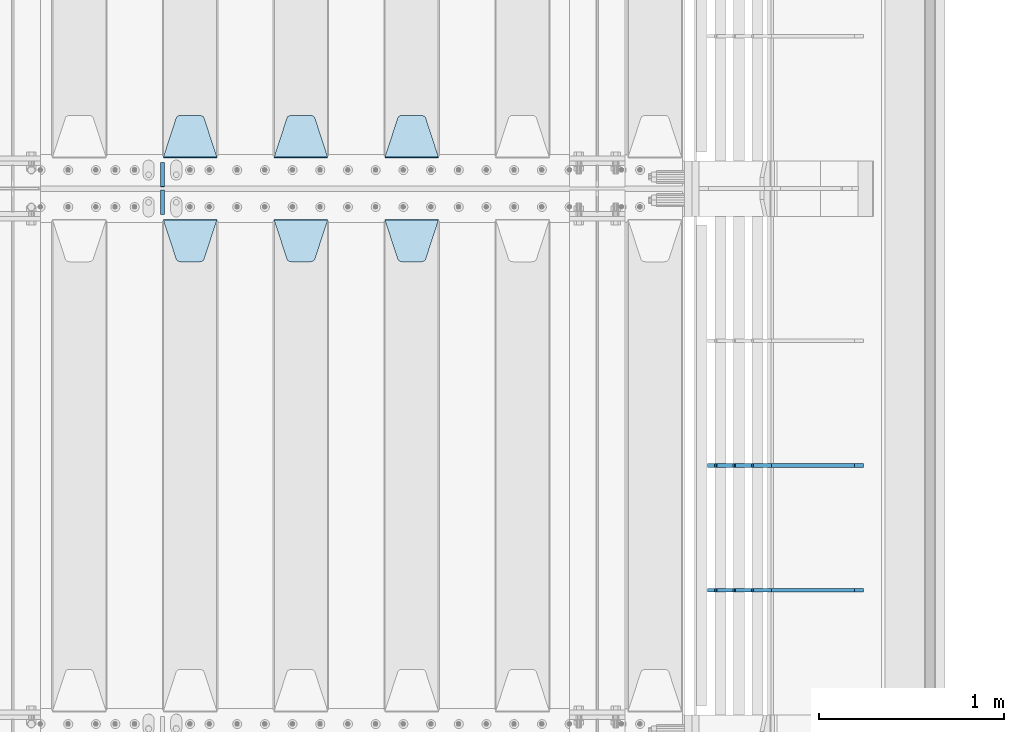
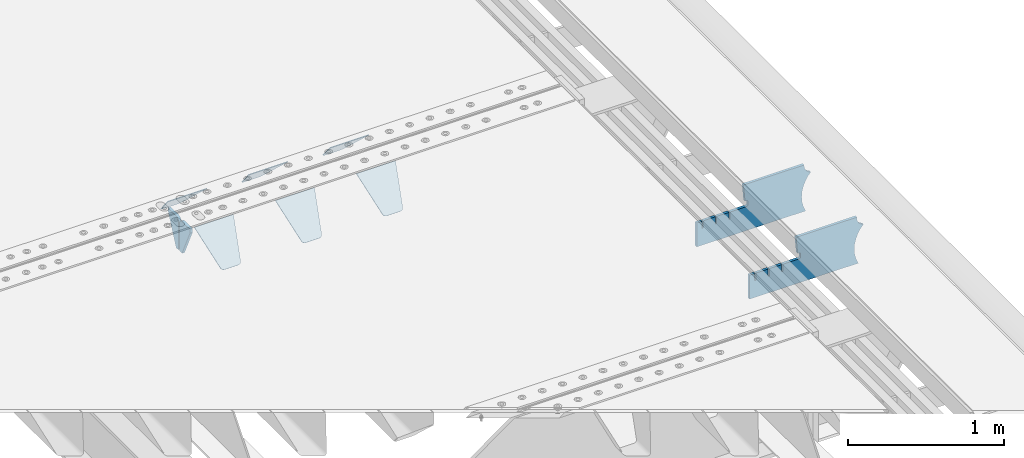
# One storey, part 207 of 240: 10 plates.
"""IFC2X3 building model written with IfcOpenShell, lengths in millimetres."""

from ifc_helpers import new_model, si_unit, frame, origin_with_axes, place, context, subcontext, project, spatial, faceted_brep, material, type_object, element, save


model = new_model("IFC2X3")

# Units and contexts
model_context = context("Model", 3, precision=1e-05, world=origin_with_axes())
body_context = subcontext(model_context, "Body", "Model", "MODEL_VIEW")
ifc_project = project(units=[si_unit("LENGTHUNIT", "METRE", prefix="MILLI"), si_unit("AREAUNIT", "SQUARE_METRE"), si_unit("VOLUMEUNIT", "CUBIC_METRE"), si_unit("MASSUNIT", "GRAM", prefix="KILO"), si_unit("TIMEUNIT", "SECOND"), si_unit("PLANEANGLEUNIT", "RADIAN"), si_unit("SOLIDANGLEUNIT", "STERADIAN"), si_unit("THERMODYNAMICTEMPERATUREUNIT", "DEGREE_CELSIUS"), si_unit("LUMINOUSINTENSITYUNIT", "LUMEN")], contexts=[model_context])

# Site, building, storey
site_placement = place(None, origin_with_axes())
site = spatial("IfcSite", under=ifc_project, at=site_placement, CompositionType="ELEMENT")
building_placement = place(site_placement, origin_with_axes())
building = spatial("IfcBuilding", under=site, at=building_placement, Name="Standard", CompositionType="ELEMENT")
storey_placement = place(building_placement, origin_with_axes())
storey = spatial("IfcBuildingStorey", under=building, at=storey_placement, Name="Undefined", CompositionType="ELEMENT", Elevation=0.0)

# Plates
ifc_material = material(Name="STEEL/S355N")
plate_type_1 = type_object("IfcPlateType", PredefinedType="NOTDEFINED")
plate_1_placement = place(storey_placement, frame((55145.0, 30168.232233047, -1.76776695296758), z_axis=(0.0, 0.707106781186547, -0.707106781186548), x_axis=(-1.0, 0.0, 0.0)))
element("IfcPlate", 1, at=plate_1_placement, inside=storey, type_object=plate_type_1, material=ifc_material, context=body_context, shape_type="Brep", body=[
    faceted_brep([(0.0, -2.5, 0.0), (69.345504679477, -2.50000000000364, 300.171731424827), (69.345504679477, 2.49999999999636, 300.171731424827), (0.0, 2.5, 0.0), (70.927406119954, -2.50000000000364, 304.897442415397), (70.927406119954, 2.49999999999636, 304.897442415397), (73.3818627772271, -2.50000000000728, 309.234538108525), (73.3818627772271, 2.49999999999636, 309.234538108529), (76.6187032999587, -2.50000000000728, 313.023683126099), (76.6187032999587, 2.49999999999636, 313.023683126103), (80.5190132705029, -2.50000000000364, 316.125672595368), (80.5190132705029, 2.49999999999636, 316.125672595368), (84.9395038596849, -2.50000000000364, 318.426546230472), (84.9395038596849, 2.49999999999636, 318.426546230472), (89.7177759439219, -2.5, 319.841774983277), (89.7177759439219, 2.49999999999636, 319.841774983273), (94.6782862926484, -2.50000000000364, 320.319366455074), (94.6782862926484, 2.49999999999636, 320.319366455074), (195.321713707352, -2.50000000000364, 320.319366455074), (195.321713707352, 2.49999999999636, 320.319366455074), (200.282224056078, -2.50000000000364, 319.841774983273), (200.282224056078, 2.49999999999636, 319.841774983273), (205.060496140315, -2.50000000000364, 318.426546230472), (205.060496140315, 2.49999999999636, 318.426546230472), (209.480986729497, -2.50000000000364, 316.125672595368), (209.480986729497, 2.49999999999636, 316.125672595368), (213.381296700041, -2.50000000000728, 313.023683126099), (213.381296700041, 2.49999999999272, 313.023683126099), (216.618137222766, -2.50000000000364, 309.234538108522), (216.618137222766, 2.49999999999636, 309.234538108522), (219.072593880039, -2.50000000000364, 304.897442415397), (219.072593880039, 2.49999999999636, 304.897442415397), (220.654495320523, -2.50000000000364, 300.171731424827), (220.654495320523, 2.49999999999636, 300.171731424827), (290.0, -2.50000000000364, -3.63797880709171e-12), (290.0, 2.49999999999636, -3.63797880709171e-12)], [[[0, 1, 2, 3]], [[1, 4, 5, 2]], [[4, 6, 7, 5]], [[6, 8, 9, 7]], [[8, 10, 11, 9]], [[10, 12, 13, 11]], [[12, 14, 15, 13]], [[14, 16, 17, 15]], [[16, 18, 19, 17]], [[18, 20, 21, 19]], [[20, 22, 23, 21]], [[22, 24, 25, 23]], [[24, 26, 27, 25]], [[26, 28, 29, 27]], [[28, 30, 31, 29]], [[30, 32, 33, 31]], [[32, 34, 35, 33]], [[34, 0, 3, 35]], [[5, 7, 9, 11, 13, 15, 17, 19, 21, 23, 25, 27, 29, 31, 33, 35, 3, 2]], [[34, 32, 30, 28, 26, 24, 22, 20, 18, 16, 14, 12, 10, 8, 6, 4, 1, 0]]]),
])
plate_2_placement = place(storey_placement, frame((54545.0, 30168.232233047, -1.76776695296758), z_axis=(0.0, 0.707106781186547, -0.707106781186548), x_axis=(-1.0, 0.0, 0.0)))
element("IfcPlate", 2, at=plate_2_placement, inside=storey, type_object=plate_type_1, material=ifc_material, context=body_context, shape_type="Brep", body=[
    faceted_brep([(0.0, -2.5, 0.0), (69.345504679477, -2.50000000000364, 300.171731424827), (69.345504679477, 2.49999999999636, 300.171731424827), (0.0, 2.5, 0.0), (70.927406119954, -2.50000000000364, 304.897442415397), (70.927406119954, 2.49999999999636, 304.897442415397), (73.3818627772271, -2.50000000000728, 309.234538108525), (73.3818627772271, 2.49999999999636, 309.234538108529), (76.6187032999587, -2.50000000000728, 313.023683126099), (76.6187032999587, 2.49999999999636, 313.023683126103), (80.5190132705029, -2.50000000000364, 316.125672595368), (80.5190132705029, 2.49999999999636, 316.125672595368), (84.9395038596849, -2.50000000000364, 318.426546230472), (84.9395038596849, 2.49999999999636, 318.426546230472), (89.7177759439219, -2.5, 319.841774983277), (89.7177759439219, 2.49999999999636, 319.841774983273), (94.6782862926484, -2.50000000000364, 320.319366455074), (94.6782862926484, 2.49999999999636, 320.319366455074), (195.321713707352, -2.50000000000364, 320.319366455074), (195.321713707352, 2.49999999999636, 320.319366455074), (200.282224056078, -2.50000000000364, 319.841774983273), (200.282224056078, 2.49999999999636, 319.841774983273), (205.060496140315, -2.50000000000364, 318.426546230472), (205.060496140315, 2.49999999999636, 318.426546230472), (209.480986729497, -2.50000000000364, 316.125672595368), (209.480986729497, 2.49999999999636, 316.125672595368), (213.381296700041, -2.50000000000728, 313.023683126099), (213.381296700041, 2.49999999999272, 313.023683126099), (216.618137222766, -2.50000000000364, 309.234538108522), (216.618137222766, 2.49999999999636, 309.234538108522), (219.072593880039, -2.50000000000364, 304.897442415397), (219.072593880039, 2.49999999999636, 304.897442415397), (220.654495320523, -2.50000000000364, 300.171731424827), (220.654495320523, 2.49999999999636, 300.171731424827), (290.0, -2.50000000000364, -3.63797880709171e-12), (290.0, 2.49999999999636, -3.63797880709171e-12)], [[[0, 1, 2, 3]], [[1, 4, 5, 2]], [[4, 6, 7, 5]], [[6, 8, 9, 7]], [[8, 10, 11, 9]], [[10, 12, 13, 11]], [[12, 14, 15, 13]], [[14, 16, 17, 15]], [[16, 18, 19, 17]], [[18, 20, 21, 19]], [[20, 22, 23, 21]], [[22, 24, 25, 23]], [[24, 26, 27, 25]], [[26, 28, 29, 27]], [[28, 30, 31, 29]], [[30, 32, 33, 31]], [[32, 34, 35, 33]], [[34, 0, 3, 35]], [[5, 7, 9, 11, 13, 15, 17, 19, 21, 23, 25, 27, 29, 31, 33, 35, 3, 2]], [[34, 32, 30, 28, 26, 24, 22, 20, 18, 16, 14, 12, 10, 8, 6, 4, 1, 0]]]),
])
plate_3_placement = place(storey_placement, frame((53945.0, 30168.232233047, -1.76776695296758), z_axis=(0.0, 0.707106781186547, -0.707106781186548), x_axis=(-1.0, 0.0, 0.0)))
element("IfcPlate", 3, at=plate_3_placement, inside=storey, type_object=plate_type_1, material=ifc_material, context=body_context, shape_type="Brep", body=[
    faceted_brep([(0.0, -2.5, 0.0), (69.345504679477, -2.50000000000364, 300.171731424827), (69.345504679477, 2.49999999999636, 300.171731424827), (0.0, 2.5, 0.0), (70.927406119954, -2.50000000000364, 304.897442415397), (70.927406119954, 2.49999999999636, 304.897442415397), (73.3818627772271, -2.50000000000728, 309.234538108525), (73.3818627772271, 2.49999999999636, 309.234538108529), (76.6187032999587, -2.50000000000728, 313.023683126099), (76.6187032999587, 2.49999999999636, 313.023683126103), (80.5190132705029, -2.50000000000364, 316.125672595368), (80.5190132705029, 2.49999999999636, 316.125672595368), (84.9395038596849, -2.50000000000364, 318.426546230472), (84.9395038596849, 2.49999999999636, 318.426546230472), (89.7177759439219, -2.5, 319.841774983277), (89.7177759439219, 2.49999999999636, 319.841774983273), (94.6782862926484, -2.50000000000364, 320.319366455074), (94.6782862926484, 2.49999999999636, 320.319366455074), (195.321713707352, -2.50000000000364, 320.319366455074), (195.321713707352, 2.49999999999636, 320.319366455074), (200.282224056078, -2.50000000000364, 319.841774983273), (200.282224056078, 2.49999999999636, 319.841774983273), (205.060496140315, -2.50000000000364, 318.426546230472), (205.060496140315, 2.49999999999636, 318.426546230472), (209.480986729497, -2.50000000000364, 316.125672595368), (209.480986729497, 2.49999999999636, 316.125672595368), (213.381296700041, -2.50000000000728, 313.023683126099), (213.381296700041, 2.49999999999272, 313.023683126099), (216.618137222766, -2.50000000000364, 309.234538108522), (216.618137222766, 2.49999999999636, 309.234538108522), (219.072593880039, -2.50000000000364, 304.897442415397), (219.072593880039, 2.49999999999636, 304.897442415397), (220.654495320523, -2.50000000000364, 300.171731424827), (220.654495320523, 2.49999999999636, 300.171731424827), (290.0, -2.50000000000364, -3.63797880709171e-12), (290.0, 2.49999999999636, -3.63797880709171e-12)], [[[0, 1, 2, 3]], [[1, 4, 5, 2]], [[4, 6, 7, 5]], [[6, 8, 9, 7]], [[8, 10, 11, 9]], [[10, 12, 13, 11]], [[12, 14, 15, 13]], [[14, 16, 17, 15]], [[16, 18, 19, 17]], [[18, 20, 21, 19]], [[20, 22, 23, 21]], [[22, 24, 25, 23]], [[24, 26, 27, 25]], [[26, 28, 29, 27]], [[28, 30, 31, 29]], [[30, 32, 33, 31]], [[32, 34, 35, 33]], [[34, 0, 3, 35]], [[5, 7, 9, 11, 13, 15, 17, 19, 21, 23, 25, 27, 29, 31, 33, 35, 3, 2]], [[34, 32, 30, 28, 26, 24, 22, 20, 18, 16, 14, 12, 10, 8, 6, 4, 1, 0]]]),
])
plate_4_placement = place(storey_placement, frame((54855.0, 29831.767766956, -1.76776695296758), z_axis=(0.0, -0.707106781186547, -0.707106781186548), x_axis=(1.0, 0.0, 0.0)))
element("IfcPlate", 4, at=plate_4_placement, inside=storey, type_object=plate_type_1, material=ifc_material, context=body_context, shape_type="Brep", body=[
    faceted_brep([(0.0, -2.5, 0.0), (69.345504679477, -2.50000000000364, 300.171731424827), (69.345504679477, 2.49999999999636, 300.171731424827), (0.0, 2.5, 0.0), (70.927406119954, -2.50000000000364, 304.897442415397), (70.927406119954, 2.49999999999636, 304.897442415397), (73.3818627772271, -2.50000000000728, 309.234538108525), (73.3818627772271, 2.49999999999636, 309.234538108529), (76.6187032999587, -2.50000000000728, 313.023683126099), (76.6187032999587, 2.49999999999636, 313.023683126103), (80.5190132705029, -2.50000000000364, 316.125672595368), (80.5190132705029, 2.49999999999636, 316.125672595368), (84.9395038596849, -2.50000000000364, 318.426546230472), (84.9395038596849, 2.49999999999636, 318.426546230472), (89.7177759439219, -2.5, 319.841774983277), (89.7177759439219, 2.49999999999636, 319.841774983273), (94.6782862926484, -2.50000000000364, 320.319366455074), (94.6782862926484, 2.49999999999636, 320.319366455074), (195.321713707352, -2.50000000000364, 320.319366455074), (195.321713707352, 2.49999999999636, 320.319366455074), (200.282224056078, -2.50000000000364, 319.841774983273), (200.282224056078, 2.49999999999636, 319.841774983273), (205.060496140315, -2.50000000000364, 318.426546230472), (205.060496140315, 2.49999999999636, 318.426546230472), (209.480986729497, -2.50000000000364, 316.125672595368), (209.480986729497, 2.49999999999636, 316.125672595368), (213.381296700041, -2.50000000000728, 313.023683126099), (213.381296700041, 2.49999999999272, 313.023683126099), (216.618137222766, -2.50000000000364, 309.234538108522), (216.618137222766, 2.49999999999636, 309.234538108522), (219.072593880039, -2.50000000000364, 304.897442415397), (219.072593880039, 2.49999999999636, 304.897442415397), (220.654495320523, -2.50000000000364, 300.171731424827), (220.654495320523, 2.49999999999636, 300.171731424827), (290.0, -2.50000000000364, -3.63797880709171e-12), (290.0, 2.49999999999636, -3.63797880709171e-12)], [[[0, 1, 2, 3]], [[1, 4, 5, 2]], [[4, 6, 7, 5]], [[6, 8, 9, 7]], [[8, 10, 11, 9]], [[10, 12, 13, 11]], [[12, 14, 15, 13]], [[14, 16, 17, 15]], [[16, 18, 19, 17]], [[18, 20, 21, 19]], [[20, 22, 23, 21]], [[22, 24, 25, 23]], [[24, 26, 27, 25]], [[26, 28, 29, 27]], [[28, 30, 31, 29]], [[30, 32, 33, 31]], [[32, 34, 35, 33]], [[34, 0, 3, 35]], [[5, 7, 9, 11, 13, 15, 17, 19, 21, 23, 25, 27, 29, 31, 33, 35, 3, 2]], [[34, 32, 30, 28, 26, 24, 22, 20, 18, 16, 14, 12, 10, 8, 6, 4, 1, 0]]]),
])
plate_5_placement = place(storey_placement, frame((54255.0, 29831.767766956, -1.76776695296758), z_axis=(0.0, -0.707106781186547, -0.707106781186548), x_axis=(1.0, 0.0, 0.0)))
element("IfcPlate", 5, at=plate_5_placement, inside=storey, type_object=plate_type_1, material=ifc_material, context=body_context, shape_type="Brep", body=[
    faceted_brep([(0.0, -2.5, 0.0), (69.345504679477, -2.50000000000364, 300.171731424827), (69.345504679477, 2.49999999999636, 300.171731424827), (0.0, 2.5, 0.0), (70.927406119954, -2.50000000000364, 304.897442415397), (70.927406119954, 2.49999999999636, 304.897442415397), (73.3818627772271, -2.50000000000728, 309.234538108525), (73.3818627772271, 2.49999999999636, 309.234538108529), (76.6187032999587, -2.50000000000728, 313.023683126099), (76.6187032999587, 2.49999999999636, 313.023683126103), (80.5190132705029, -2.50000000000364, 316.125672595368), (80.5190132705029, 2.49999999999636, 316.125672595368), (84.9395038596849, -2.50000000000364, 318.426546230472), (84.9395038596849, 2.49999999999636, 318.426546230472), (89.7177759439219, -2.5, 319.841774983277), (89.7177759439219, 2.49999999999636, 319.841774983273), (94.6782862926484, -2.50000000000364, 320.319366455074), (94.6782862926484, 2.49999999999636, 320.319366455074), (195.321713707352, -2.50000000000364, 320.319366455074), (195.321713707352, 2.49999999999636, 320.319366455074), (200.282224056078, -2.50000000000364, 319.841774983273), (200.282224056078, 2.49999999999636, 319.841774983273), (205.060496140315, -2.50000000000364, 318.426546230472), (205.060496140315, 2.49999999999636, 318.426546230472), (209.480986729497, -2.50000000000364, 316.125672595368), (209.480986729497, 2.49999999999636, 316.125672595368), (213.381296700041, -2.50000000000728, 313.023683126099), (213.381296700041, 2.49999999999272, 313.023683126099), (216.618137222766, -2.50000000000364, 309.234538108522), (216.618137222766, 2.49999999999636, 309.234538108522), (219.072593880039, -2.50000000000364, 304.897442415397), (219.072593880039, 2.49999999999636, 304.897442415397), (220.654495320523, -2.50000000000364, 300.171731424827), (220.654495320523, 2.49999999999636, 300.171731424827), (290.0, -2.50000000000364, -3.63797880709171e-12), (290.0, 2.49999999999636, -3.63797880709171e-12)], [[[0, 1, 2, 3]], [[1, 4, 5, 2]], [[4, 6, 7, 5]], [[6, 8, 9, 7]], [[8, 10, 11, 9]], [[10, 12, 13, 11]], [[12, 14, 15, 13]], [[14, 16, 17, 15]], [[16, 18, 19, 17]], [[18, 20, 21, 19]], [[20, 22, 23, 21]], [[22, 24, 25, 23]], [[24, 26, 27, 25]], [[26, 28, 29, 27]], [[28, 30, 31, 29]], [[30, 32, 33, 31]], [[32, 34, 35, 33]], [[34, 0, 3, 35]], [[5, 7, 9, 11, 13, 15, 17, 19, 21, 23, 25, 27, 29, 31, 33, 35, 3, 2]], [[34, 32, 30, 28, 26, 24, 22, 20, 18, 16, 14, 12, 10, 8, 6, 4, 1, 0]]]),
])
plate_6_placement = place(storey_placement, frame((53655.0, 29831.767766956, -1.76776695296758), z_axis=(0.0, -0.707106781186547, -0.707106781186548), x_axis=(1.0, 0.0, 0.0)))
element("IfcPlate", 6, at=plate_6_placement, inside=storey, type_object=plate_type_1, material=ifc_material, context=body_context, shape_type="Brep", body=[
    faceted_brep([(0.0, -2.5, 0.0), (69.345504679477, -2.50000000000364, 300.171731424827), (69.345504679477, 2.49999999999636, 300.171731424827), (0.0, 2.5, 0.0), (70.927406119954, -2.50000000000364, 304.897442415397), (70.927406119954, 2.49999999999636, 304.897442415397), (73.3818627772271, -2.50000000000728, 309.234538108525), (73.3818627772271, 2.49999999999636, 309.234538108529), (76.6187032999587, -2.50000000000728, 313.023683126099), (76.6187032999587, 2.49999999999636, 313.023683126103), (80.5190132705029, -2.50000000000364, 316.125672595368), (80.5190132705029, 2.49999999999636, 316.125672595368), (84.9395038596849, -2.50000000000364, 318.426546230472), (84.9395038596849, 2.49999999999636, 318.426546230472), (89.7177759439219, -2.5, 319.841774983277), (89.7177759439219, 2.49999999999636, 319.841774983273), (94.6782862926484, -2.50000000000364, 320.319366455074), (94.6782862926484, 2.49999999999636, 320.319366455074), (195.321713707352, -2.50000000000364, 320.319366455074), (195.321713707352, 2.49999999999636, 320.319366455074), (200.282224056078, -2.50000000000364, 319.841774983273), (200.282224056078, 2.49999999999636, 319.841774983273), (205.060496140315, -2.50000000000364, 318.426546230472), (205.060496140315, 2.49999999999636, 318.426546230472), (209.480986729497, -2.50000000000364, 316.125672595368), (209.480986729497, 2.49999999999636, 316.125672595368), (213.381296700041, -2.50000000000728, 313.023683126099), (213.381296700041, 2.49999999999272, 313.023683126099), (216.618137222766, -2.50000000000364, 309.234538108522), (216.618137222766, 2.49999999999636, 309.234538108522), (219.072593880039, -2.50000000000364, 304.897442415397), (219.072593880039, 2.49999999999636, 304.897442415397), (220.654495320523, -2.50000000000364, 300.171731424827), (220.654495320523, 2.49999999999636, 300.171731424827), (290.0, -2.50000000000364, -3.63797880709171e-12), (290.0, 2.49999999999636, -3.63797880709171e-12)], [[[0, 1, 2, 3]], [[1, 4, 5, 2]], [[4, 6, 7, 5]], [[6, 8, 9, 7]], [[8, 10, 11, 9]], [[10, 12, 13, 11]], [[12, 14, 15, 13]], [[14, 16, 17, 15]], [[16, 18, 19, 17]], [[18, 20, 21, 19]], [[20, 22, 23, 21]], [[22, 24, 25, 23]], [[24, 26, 27, 25]], [[26, 28, 29, 27]], [[28, 30, 31, 29]], [[30, 32, 33, 31]], [[32, 34, 35, 33]], [[34, 0, 3, 35]], [[5, 7, 9, 11, 13, 15, 17, 19, 21, 23, 25, 27, 29, 31, 33, 35, 3, 2]], [[34, 32, 30, 28, 26, 24, 22, 20, 18, 16, 14, 12, 10, 8, 6, 4, 1, 0]]]),
])
plate_type_2 = type_object("IfcPlateType", PredefinedType="NOTDEFINED")
for number, where, z_axis, x_axis in (
    (7, (53650.0, 30140.0, -30.0), (0.0, 0.0, -1.0), (0.0, -1.0, 0.0)),
    (8, (53650.0, 29860.0, -30.0), (0.0, 0.0, -1.0), (0.0, 1.0, 0.0)),
):
    element("IfcPlate", number, at=place(storey_placement, frame(where, z_axis=z_axis, x_axis=x_axis)), inside=storey, type_object=plate_type_2, material=ifc_material, context=body_context, shape_type="Brep", body=[
        faceted_brep([(0.0, -10.0, 0.0), (0.0, -10.0, 30.0), (0.0, 10.0, 30.0), (0.0, 10.0, 0.0), (102.0, -10.0, 250.0), (102.0, 10.0, 250.0), (132.0, -10.0, 250.0), (132.0, 10.0, 250.0), (132.0, -10.0, 30.0), (132.0, 10.0, 30.0), (131.544232590368, -10.0, 24.790554669992), (131.544232590368, 10.0, 24.790554669992), (130.190778623579, -10.0, 19.7393957002299), (130.190778623579, 10.0, 19.7393957002299), (127.980762113533, -10.0, 15.0), (127.980762113533, 10.0, 15.0), (124.98133329357, -10.0, 10.7163717094038), (124.98133329357, 10.0, 10.7163717094038), (121.283628290596, -10.0, 7.01866670643062), (121.283628290596, 10.0, 7.01866670643062), (117.0, -10.0, 4.01923788646684), (117.0, 10.0, 4.01923788646684), (112.260604299769, -10.0, 1.80922137642278), (112.260604299769, 10.0, 1.80922137642278), (107.209445330009, -10.0, 0.455767409633722), (107.209445330009, 10.0, 0.455767409633722), (102.0, -10.0, 0.0), (102.0, 10.0, 0.0)], [[[0, 1, 2, 3]], [[1, 4, 5, 2]], [[4, 6, 7, 5]], [[6, 8, 9, 7]], [[8, 10, 11, 9]], [[10, 12, 13, 11]], [[12, 14, 15, 13]], [[14, 16, 17, 15]], [[16, 18, 19, 17]], [[18, 20, 21, 19]], [[20, 22, 23, 21]], [[22, 24, 25, 23]], [[24, 26, 27, 25]], [[26, 0, 3, 27]], [[5, 7, 9, 11, 13, 15, 17, 19, 21, 23, 25, 27, 3, 2]], [[26, 24, 22, 20, 18, 16, 14, 12, 10, 8, 6, 4, 1, 0]]]),
    ])
plate_type_3 = type_object("IfcPlateType", PredefinedType="NOTDEFINED")
plate_7_placement = place(storey_placement, frame((57442.9182339676, 27824.9992828369, -374.002067436517), z_axis=(0.0, 0.0, 1.0), x_axis=(-1.0, 0.0, 0.0)))
element("IfcPlate", 9, at=plate_7_placement, inside=storey, type_object=plate_type_3, material=ifc_material, context=body_context, shape_type="Brep", body=[
    faceted_brep([(801.919404066546, -10.0, 188.0), (801.919404066546, 10.0, 188.0), (801.919404066546, 10.0, 132.002067436952), (801.919404066546, -10.0, 132.002067436952), (793.919404066546, 10.0, 132.002067436952), (793.919404066546, -10.0, 132.002067436952), (793.919404066546, 10.0, 180.002067436952), (793.919404066546, -10.0, 180.002067436952), (793.52785619691, 10.0, 182.474203391951), (793.52785619691, -10.0, 182.474203391951), (792.391540021548, 10.0, 184.704349455291), (792.391540021548, -10.0, 184.704349455291), (790.621686084887, 10.0, 186.474203391951), (790.621686084887, -10.0, 186.474203391951), (788.391540021548, 10.0, 187.610519567313), (788.391540021548, -10.0, 187.610519567313), (785.919404066546, -10.0, 188.002067436952), (785.919404066546, 10.0, 188.0), (841.0, -10.0, 188.0), (841.0, -10.0, 0.0), (841.0, 10.0, 0.0), (841.0, 10.0, 188.0), (33.3619566735943, -10.0, 0.0), (33.3619566735943, 10.0, 0.0), (36.2350612208102, -10.0, 4.68848050267013), (36.2350612208102, 10.0, 4.68848050267013), (51.4877592159319, -10.0, 41.5117508652784), (51.4877592159319, 10.0, 41.5117508652784), (60.7922425881334, -10.0, 80.2677133162964), (60.7922425881334, 10.0, 80.2677133162964), (63.9194040769653, -10.0, 120.002067436515), (63.9194040769653, 10.0, 120.002067436515), (60.7922425881334, -10.0, 159.736421556734), (60.7922425881334, 10.0, 159.736421556734), (51.4877592159319, -10.0, 198.492384007752), (51.4877592159319, 10.0, 198.492384007752), (36.2350612208102, -10.0, 235.31565437036), (36.2350612208102, 10.0, 235.31565437036), (15.4097206482038, -10.0, 269.299521518803), (15.4097206482038, 10.0, 269.299521518803), (-3.35474438100209, -10.0, 291.269887256574), (-3.35474438100209, 10.0, 291.269887256574), (-2.36881039375294, -10.0000000000036, 291.426043859339), (-2.36881039375294, 10.0, 291.426043859339), (17.1449676604752, -10.0000000000036, 301.368810393754), (17.1449676604752, 10.0, 301.368810393754), (32.6311896062471, -10.0000000000036, 316.855032339527), (32.6311896062471, 10.0, 316.855032339527), (42.573956140659, -10.0000000000036, 336.368810393754), (42.573956140659, 10.0, 336.368810393754), (46.0, -10.0000000000036, 358.0), (46.0, 10.0, 358.0), (45.0495205499246, -10.0, 364.001091067617), (45.0495205499246, 10.0, 364.001091067617), (495.040008544922, -10.0, 364.010009765625), (495.040008544922, 10.0, 364.010009765625), (483.600036621094, -10.0, 233.759994506836), (483.600036621094, 10.0, 233.759994506836), (472.0, -10.0, 233.759994506836), (472.0, 10.0, 233.759994506836), (468.909830056247, -10.0, 233.270559669787), (468.909830056247, 10.0, 233.270559669787), (466.122147477072, -10.0, 231.850164450585), (466.122147477072, 10.0, 231.850164450585), (463.909830056247, -10.0, 229.637847029761), (463.909830056247, 10.0, 229.637847029761), (462.489434837051, -10.0, 226.850164450585), (462.489434837051, 10.0, 226.850164450585), (462.0, -10.0, 223.759994506836), (462.0, 10.0, 223.759994506836), (462.0, -10.0, 198.0), (462.0, 10.0, 198.0), (462.489434837051, -10.0, 194.909830056251), (462.489434837051, 10.0, 194.909830056251), (463.909830056247, -10.0, 192.122147477075), (463.909830056247, 10.0, 192.122147477075), (466.122147477072, -10.0, 189.909830056251), (466.122147477072, 10.0, 189.909830056251), (468.909830056247, -10.0, 188.489434837048), (468.909830056247, 10.0, 188.489434837048), (472.0, -10.0, 188.0), (472.0, 10.0, 188.0), (585.919404066546, -10.0, 188.002067436952), (585.919404066546, 10.0, 188.0), (588.391540021548, -9.99999999999636, 187.610519567313), (588.391540021548, 10.0, 187.610519567313), (590.621686084887, -9.99999999999636, 186.474203391951), (590.621686084887, 10.0, 186.474203391951), (592.391540021548, -9.99999999999636, 184.704349455291), (592.391540021548, 10.0, 184.704349455291), (593.52785619691, -9.99999999999636, 182.474203391951), (593.52785619691, 10.0, 182.474203391951), (593.919404066546, -9.99999999999636, 180.002067436952), (593.919404066546, 10.0, 180.002067436952), (593.919404066546, -9.99999999999636, 132.002067436952), (593.919404066546, 10.0, 132.002067436952), (601.919404066546, -9.99999999999636, 132.002067436952), (601.919404066546, 10.0, 132.002067436952), (601.919404066546, -10.0, 188.0), (601.919404066546, 10.0, 188.0), (685.919404066546, -10.0, 188.002067436952), (685.919404066546, 10.0, 188.0), (688.391540021548, -10.0, 187.610519567313), (688.391540021548, 10.0, 187.610519567313), (690.621686084887, -10.0, 186.474203391951), (690.621686084887, 10.0, 186.474203391951), (692.391540021548, -10.0, 184.704349455291), (692.391540021548, 10.0, 184.704349455291), (693.52785619691, -10.0, 182.474203391951), (693.52785619691, 10.0, 182.474203391951), (693.919404066546, -10.0, 180.002067436952), (693.919404066546, 10.0, 180.002067436952), (693.919404066546, -10.0, 132.002067436952), (693.919404066546, 10.0000000000036, 132.002067436952), (701.919404066546, -10.0, 132.002067436952), (701.919404066546, 10.0000000000036, 132.002067436952), (701.919404066546, -10.0, 188.0), (701.919404066546, 10.0, 188.0)], [[[0, 1, 2, 3]], [[3, 2, 4, 5]], [[5, 4, 6, 7]], [[7, 6, 8, 9]], [[9, 8, 10, 11]], [[11, 10, 12, 13]], [[13, 12, 14, 15]], [[16, 15, 14, 17]], [[18, 19, 20, 21]], [[20, 19, 22, 23]], [[22, 24, 25, 23]], [[26, 27, 25, 24]], [[28, 29, 27, 26]], [[30, 31, 29, 28]], [[32, 33, 31, 30]], [[34, 35, 33, 32]], [[36, 37, 35, 34]], [[38, 39, 37, 36]], [[39, 38, 40, 41]], [[40, 42, 43, 41]], [[44, 45, 43, 42]], [[46, 47, 45, 44]], [[48, 49, 47, 46]], [[50, 51, 49, 48]], [[52, 53, 51, 50]], [[54, 55, 53, 52]], [[54, 56, 57, 55]], [[56, 58, 59, 57]], [[58, 60, 61, 59]], [[60, 62, 63, 61]], [[62, 64, 65, 63]], [[64, 66, 67, 65]], [[66, 68, 69, 67]], [[68, 70, 71, 69]], [[70, 72, 73, 71]], [[72, 74, 75, 73]], [[74, 76, 77, 75]], [[76, 78, 79, 77]], [[78, 80, 81, 79]], [[81, 80, 82, 83]], [[82, 84, 85, 83]], [[86, 87, 85, 84]], [[88, 89, 87, 86]], [[90, 91, 89, 88]], [[92, 93, 91, 90]], [[94, 95, 93, 92]], [[96, 97, 95, 94]], [[98, 99, 97, 96]], [[99, 98, 100, 101]], [[100, 102, 103, 101]], [[104, 105, 103, 102]], [[106, 107, 105, 104]], [[108, 109, 107, 106]], [[110, 111, 109, 108]], [[112, 113, 111, 110]], [[114, 115, 113, 112]], [[116, 117, 115, 114]], [[117, 116, 16, 17]], [[12, 10, 8, 6, 4, 2, 1, 21, 20, 23, 25, 27, 29, 31, 33, 35, 37, 39, 41, 43, 45, 47, 49, 51, 53, 55, 57, 59, 61, 63, 65, 67, 69, 71, 73, 75, 77, 79, 81, 83, 85, 87, 89, 91, 93, 95, 97, 99, 101, 103, 105, 107, 109, 111, 113, 115, 117, 17, 14]], [[18, 21, 1, 0]], [[116, 114, 112, 110, 108, 106, 104, 102, 100, 98, 96, 94, 92, 90, 88, 86, 84, 82, 80, 78, 76, 74, 72, 70, 68, 66, 64, 62, 60, 58, 56, 54, 52, 50, 48, 46, 44, 42, 40, 38, 36, 34, 32, 30, 28, 26, 24, 22, 19, 18, 0, 3, 5, 7, 9, 11, 13, 15, 16]]]),
])
plate_8_placement = place(storey_placement, frame((57442.9182339676, 28499.9992828369, -374.002067436517), z_axis=(0.0, 0.0, 1.0), x_axis=(-1.0, 0.0, 0.0)))
element("IfcPlate", 10, at=plate_8_placement, inside=storey, type_object=plate_type_3, material=ifc_material, context=body_context, shape_type="Brep", body=[
    faceted_brep([(801.919404066546, -10.0, 188.0), (801.919404066546, 10.0, 188.0), (801.919404066546, 10.0, 132.002067436952), (801.919404066546, -10.0, 132.002067436952), (793.919404066546, 10.0, 132.002067436952), (793.919404066546, -10.0, 132.002067436952), (793.919404066546, 10.0, 180.002067436952), (793.919404066546, -10.0, 180.002067436952), (793.52785619691, 10.0, 182.474203391951), (793.52785619691, -10.0, 182.474203391951), (792.391540021548, 10.0, 184.704349455291), (792.391540021548, -10.0, 184.704349455291), (790.621686084887, 10.0, 186.474203391951), (790.621686084887, -10.0, 186.474203391951), (788.391540021548, 10.0, 187.610519567313), (788.391540021548, -10.0, 187.610519567313), (785.919404066546, -10.0, 188.002067436952), (785.919404066546, 10.0, 188.0), (841.0, -10.0, 188.0), (841.0, -10.0, 0.0), (841.0, 10.0, 0.0), (841.0, 10.0, 188.0), (33.3619566735943, -10.0, 0.0), (33.3619566735943, 10.0, 0.0), (36.2350612208102, -10.0, 4.68848050267013), (36.2350612208102, 10.0, 4.68848050267013), (51.4877592159319, -10.0, 41.5117508652784), (51.4877592159319, 10.0, 41.5117508652784), (60.7922425881334, -10.0, 80.2677133162964), (60.7922425881334, 10.0, 80.2677133162964), (63.9194040769653, -10.0, 120.002067436515), (63.9194040769653, 10.0, 120.002067436515), (60.7922425881334, -10.0, 159.736421556734), (60.7922425881334, 10.0, 159.736421556734), (51.4877592159319, -10.0, 198.492384007752), (51.4877592159319, 10.0, 198.492384007752), (36.2350612208102, -10.0, 235.31565437036), (36.2350612208102, 10.0, 235.31565437036), (15.4097206482038, -10.0, 269.299521518803), (15.4097206482038, 10.0, 269.299521518803), (-3.35474438100209, -10.0, 291.269887256574), (-3.35474438100209, 10.0, 291.269887256574), (-2.36881039375294, -10.0000000000036, 291.426043859339), (-2.36881039375294, 10.0, 291.426043859339), (17.1449676604752, -10.0000000000036, 301.368810393754), (17.1449676604752, 10.0, 301.368810393754), (32.6311896062471, -10.0000000000036, 316.855032339527), (32.6311896062471, 10.0, 316.855032339527), (42.573956140659, -10.0000000000036, 336.368810393754), (42.573956140659, 10.0, 336.368810393754), (46.0, -10.0000000000036, 358.0), (46.0, 10.0, 358.0), (45.0495205499246, -10.0, 364.001091067617), (45.0495205499246, 10.0, 364.001091067617), (495.040008544922, -10.0, 364.010009765625), (495.040008544922, 10.0, 364.010009765625), (483.600036621094, -10.0, 233.759994506836), (483.600036621094, 10.0, 233.759994506836), (472.0, -10.0, 233.759994506836), (472.0, 10.0, 233.759994506836), (468.909830056247, -10.0, 233.270559669787), (468.909830056247, 10.0, 233.270559669787), (466.122147477072, -10.0, 231.850164450585), (466.122147477072, 10.0, 231.850164450585), (463.909830056247, -10.0, 229.637847029761), (463.909830056247, 10.0, 229.637847029761), (462.489434837051, -10.0, 226.850164450585), (462.489434837051, 10.0, 226.850164450585), (462.0, -10.0, 223.759994506836), (462.0, 10.0, 223.759994506836), (462.0, -10.0, 198.0), (462.0, 10.0, 198.0), (462.489434837051, -10.0, 194.909830056251), (462.489434837051, 10.0, 194.909830056251), (463.909830056247, -10.0, 192.122147477075), (463.909830056247, 10.0, 192.122147477075), (466.122147477072, -10.0, 189.909830056251), (466.122147477072, 10.0, 189.909830056251), (468.909830056247, -10.0, 188.489434837048), (468.909830056247, 10.0, 188.489434837048), (472.0, -10.0, 188.0), (472.0, 10.0, 188.0), (585.919404066546, -10.0, 188.002067436952), (585.919404066546, 10.0, 188.0), (588.391540021548, -9.99999999999636, 187.610519567313), (588.391540021548, 10.0, 187.610519567313), (590.621686084887, -9.99999999999636, 186.474203391951), (590.621686084887, 10.0, 186.474203391951), (592.391540021548, -9.99999999999636, 184.704349455291), (592.391540021548, 10.0, 184.704349455291), (593.52785619691, -9.99999999999636, 182.474203391951), (593.52785619691, 10.0, 182.474203391951), (593.919404066546, -9.99999999999636, 180.002067436952), (593.919404066546, 10.0, 180.002067436952), (593.919404066546, -9.99999999999636, 132.002067436952), (593.919404066546, 10.0, 132.002067436952), (601.919404066546, -9.99999999999636, 132.002067436952), (601.919404066546, 10.0, 132.002067436952), (601.919404066546, -10.0, 188.0), (601.919404066546, 10.0, 188.0), (685.919404066546, -10.0, 188.002067436952), (685.919404066546, 10.0, 188.0), (688.391540021548, -10.0, 187.610519567313), (688.391540021548, 10.0, 187.610519567313), (690.621686084887, -10.0, 186.474203391951), (690.621686084887, 10.0, 186.474203391951), (692.391540021548, -10.0, 184.704349455291), (692.391540021548, 10.0, 184.704349455291), (693.52785619691, -10.0, 182.474203391951), (693.52785619691, 10.0, 182.474203391951), (693.919404066546, -10.0, 180.002067436952), (693.919404066546, 10.0, 180.002067436952), (693.919404066546, -10.0, 132.002067436952), (693.919404066546, 10.0000000000036, 132.002067436952), (701.919404066546, -10.0, 132.002067436952), (701.919404066546, 10.0000000000036, 132.002067436952), (701.919404066546, -10.0, 188.0), (701.919404066546, 10.0, 188.0)], [[[0, 1, 2, 3]], [[3, 2, 4, 5]], [[5, 4, 6, 7]], [[7, 6, 8, 9]], [[9, 8, 10, 11]], [[11, 10, 12, 13]], [[13, 12, 14, 15]], [[16, 15, 14, 17]], [[18, 19, 20, 21]], [[20, 19, 22, 23]], [[22, 24, 25, 23]], [[26, 27, 25, 24]], [[28, 29, 27, 26]], [[30, 31, 29, 28]], [[32, 33, 31, 30]], [[34, 35, 33, 32]], [[36, 37, 35, 34]], [[38, 39, 37, 36]], [[39, 38, 40, 41]], [[40, 42, 43, 41]], [[44, 45, 43, 42]], [[46, 47, 45, 44]], [[48, 49, 47, 46]], [[50, 51, 49, 48]], [[52, 53, 51, 50]], [[54, 55, 53, 52]], [[54, 56, 57, 55]], [[56, 58, 59, 57]], [[58, 60, 61, 59]], [[60, 62, 63, 61]], [[62, 64, 65, 63]], [[64, 66, 67, 65]], [[66, 68, 69, 67]], [[68, 70, 71, 69]], [[70, 72, 73, 71]], [[72, 74, 75, 73]], [[74, 76, 77, 75]], [[76, 78, 79, 77]], [[78, 80, 81, 79]], [[81, 80, 82, 83]], [[82, 84, 85, 83]], [[86, 87, 85, 84]], [[88, 89, 87, 86]], [[90, 91, 89, 88]], [[92, 93, 91, 90]], [[94, 95, 93, 92]], [[96, 97, 95, 94]], [[98, 99, 97, 96]], [[99, 98, 100, 101]], [[100, 102, 103, 101]], [[104, 105, 103, 102]], [[106, 107, 105, 104]], [[108, 109, 107, 106]], [[110, 111, 109, 108]], [[112, 113, 111, 110]], [[114, 115, 113, 112]], [[116, 117, 115, 114]], [[117, 116, 16, 17]], [[12, 10, 8, 6, 4, 2, 1, 21, 20, 23, 25, 27, 29, 31, 33, 35, 37, 39, 41, 43, 45, 47, 49, 51, 53, 55, 57, 59, 61, 63, 65, 67, 69, 71, 73, 75, 77, 79, 81, 83, 85, 87, 89, 91, 93, 95, 97, 99, 101, 103, 105, 107, 109, 111, 113, 115, 117, 17, 14]], [[18, 21, 1, 0]], [[116, 114, 112, 110, 108, 106, 104, 102, 100, 98, 96, 94, 92, 90, 88, 86, 84, 82, 80, 78, 76, 74, 72, 70, 68, 66, 64, 62, 60, 58, 56, 54, 52, 50, 48, 46, 44, 42, 40, 38, 36, 34, 32, 30, 28, 26, 24, 22, 19, 18, 0, 3, 5, 7, 9, 11, 13, 15, 16]]]),
])

save(model, "model.ifc")
